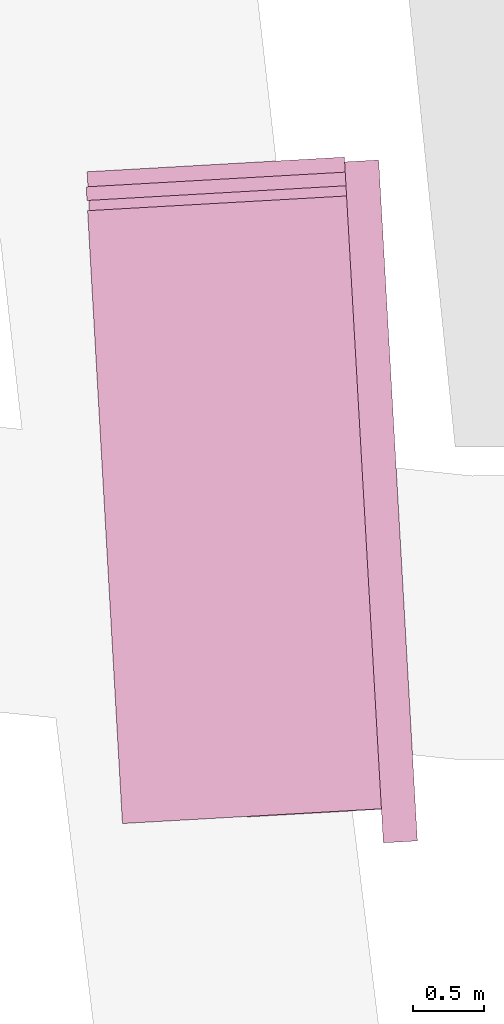
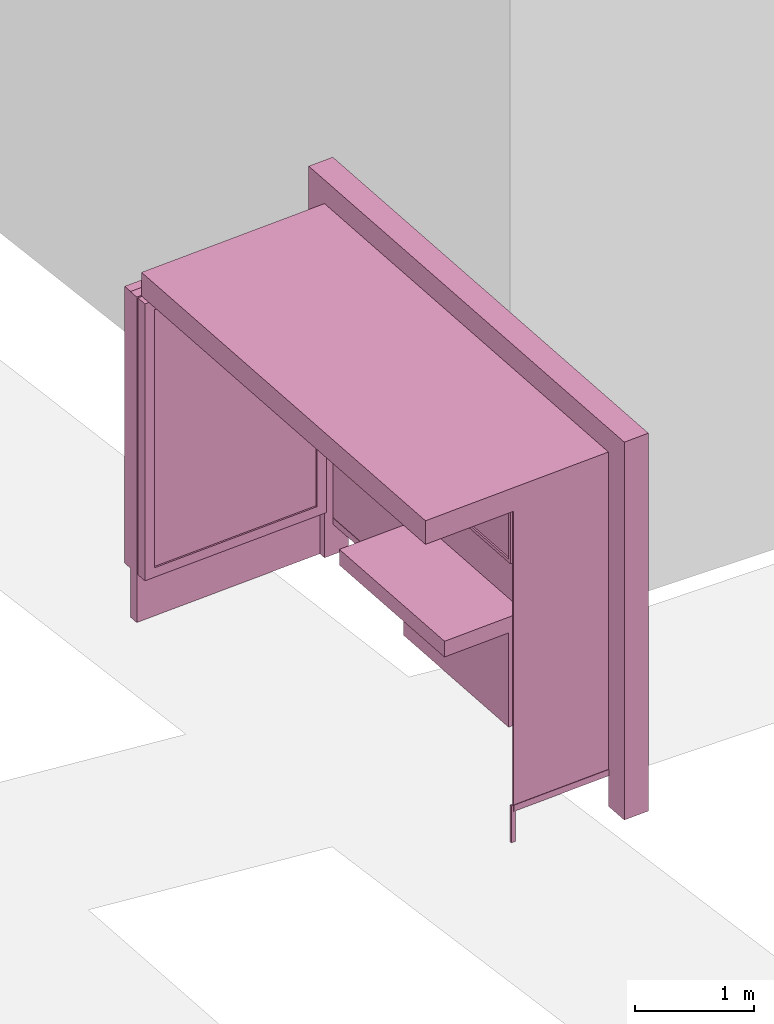
# One storey, part 32 of 200: 1 furnishing.
"""IFC4 building model written with IfcOpenShell, lengths in metres."""

import ifcopenshell
import ifcopenshell.guid

model = None  # the IFC model being written
_history = None  # IfcOwnerHistory: only IFC2X3 demands one
_inside = {}  # id of a spatial element -> (the spatial element, [elements in it])
_under = {}  # id of a project, library or spatial element -> (it, [spatial elements below it])
_declared = {}  # id of a project -> (the project, [libraries it declares])
_typed = {}  # id of a type object -> (the type object, [elements of that type])
_made_of = {}  # id of a material, layer set ... -> (it, [elements and type objects made of it])


def new_model(schema):
    """Start an empty IFC model of exactly this schema.

    Asked for "IFC4X3", IfcOpenShell would pick the latest addendum, in which some entities
    have other attributes; the version numbers below select the first issue.
    IFC2X3 requires an IfcOwnerHistory on every rooted entity: one is made here for all.
    """
    global model, _history
    if schema == "IFC4X3":
        model = ifcopenshell.file(schema_version=(4, 3, 0, 0))
    else:
        model = ifcopenshell.file(schema=schema)
    _inside.clear()
    _under.clear()
    _declared.clear()
    _typed.clear()
    _made_of.clear()
    _history = None
    if model.schema == "IFC2X3":
        org = make("IfcOrganization", Name="unknown")
        user = make(
            "IfcPersonAndOrganization",
            ThePerson=make("IfcPerson", FamilyName="unknown"),
            TheOrganization=org,
        )
        app = make(
            "IfcApplication",
            ApplicationDeveloper=org,
            Version="unknown",
            ApplicationFullName="unknown",
            ApplicationIdentifier="unknown",
        )
        _history = make(
            "IfcOwnerHistory",
            OwningUser=user,
            OwningApplication=app,
            ChangeAction="ADDED",
            CreationDate=0,
        )
    return model


def make(cls, **values):
    """One entity of the class cls with the attributes given. An attribute that is None is left unset."""
    return model.create_entity(
        cls, **{name: value for name, value in values.items() if value is not None}
    )


def rooted(cls, **values):
    """An entity with a GlobalId (a new one), such as an element, a storey or a relation."""
    return make(cls, GlobalId=ifcopenshell.guid.new(), OwnerHistory=_history, **values)


def si_unit(unit_type, name, prefix=None):
    """IfcSIUnit, for example si_unit("LENGTHUNIT", "METRE", prefix="MILLI")."""
    return make("IfcSIUnit", UnitType=unit_type, Prefix=prefix, Name=name)


def assignment(units):
    """IfcUnitAssignment: the units of a project."""
    return None if units is None else make("IfcUnitAssignment", Units=units)


def point(xyz):
    """IfcCartesianPoint."""
    return None if xyz is None else make("IfcCartesianPoint", Coordinates=xyz)


def direction(xyz):
    """IfcDirection."""
    return None if xyz is None else make("IfcDirection", DirectionRatios=xyz)


def frame(location, z_axis=None, x_axis=None):
    """IfcAxis2Placement3D, a coordinate frame: its origin and axes. An axis left out is left unset."""
    return make(
        "IfcAxis2Placement3D",
        Location=point(location),
        Axis=direction(z_axis),
        RefDirection=direction(x_axis),
    )


def origin_with_axes():
    """The frame at (0, 0, 0) with the z axis (0, 0, 1) and the x axis (1, 0, 0) written out."""
    return frame((0.0, 0.0, 0.0), z_axis=(0.0, 0.0, 1.0), x_axis=(1.0, 0.0, 0.0))


def place(relative_to, where):
    """IfcLocalPlacement: puts the frame where relative to a parent placement (None: the world)."""
    return make(
        "IfcLocalPlacement", PlacementRelTo=relative_to, RelativePlacement=where
    )


def context(
    kind, dimensions, precision=None, world=None, true_north=None, identifier=None
):
    """IfcGeometricRepresentationContext, for example the 3D "Model" context."""
    return make(
        "IfcGeometricRepresentationContext",
        ContextIdentifier=identifier,
        ContextType=kind,
        CoordinateSpaceDimension=dimensions,
        Precision=precision,
        WorldCoordinateSystem=world,
        TrueNorth=true_north,
    )


def subcontext(parent, identifier, kind, view, scale=None):
    """IfcGeometricRepresentationSubContext, for example "Body" below "Model"."""
    return make(
        "IfcGeometricRepresentationSubContext",
        ContextIdentifier=identifier,
        ContextType=kind,
        ParentContext=parent,
        TargetScale=scale,
        TargetView=view,
    )


def project(units=None, contexts=None):
    """IfcProject with its units and contexts."""
    return rooted(
        "IfcProject",
        Name="project",
        RepresentationContexts=contexts,
        UnitsInContext=assignment(units),
    )


def spatial(cls, under=None, at=None, **own):
    """A site, building, storey or space (cls), placed at a placement, below another one or the project."""
    s = rooted(cls, ObjectPlacement=at, **own)
    if under is not None:
        _under.setdefault(under.id(), (under, []))[1].append(s)
    return s


def point_list(points):
    """IfcCartesianPointList2D or 3D."""
    cls = (
        "IfcCartesianPointList2D" if len(points[0]) == 2 else "IfcCartesianPointList3D"
    )
    return make(cls, CoordList=points)


def triangles(points, corners, closed=None, point_numbers=None):
    """IfcTriangulatedFaceSet: each triangle names its three corners, points numbered from 1."""
    return make(
        "IfcTriangulatedFaceSet",
        Coordinates=point_list(points),
        Closed=closed,
        CoordIndex=corners,
        PnIndex=point_numbers,
    )


def shape(context_of_items, identifier, shape_type, items):
    """IfcShapeRepresentation: the items that make up one representation, for example the "Body"."""
    return make(
        "IfcShapeRepresentation",
        ContextOfItems=context_of_items,
        RepresentationIdentifier=identifier,
        RepresentationType=shape_type,
        Items=items,
    )


def material(Name=None, Category=None):
    """IfcMaterial."""
    return make("IfcMaterial", Name=Name, Category=Category)


def made_of(thing, what):
    """Note that an element or type object is made of a material, layer set ...; save() writes the relation."""
    if what is not None:
        _made_of.setdefault(what.id(), (what, []))[1].append(thing)
    return thing


def element(
    cls,
    number,
    at=None,
    inside=None,
    cuts=None,
    type_object=None,
    material=None,
    context=None,
    identifier="Body",
    shape_type=None,
    held_by="IfcProductDefinitionShape",
    body=None,
    shapes=None,
    **own,
):
    """One element of the class cls, such as IfcWall. Its Tag is "e" and its number.

    at: its placement. inside: the storey or other place that contains it. cuts: it is an
    opening in that element (IfcRelVoidsElement). A single representation is given by context,
    identifier, shape_type and body (its items); several are given by shapes. held_by: the class
    of the entity that holds the representations. save() writes the other relations.
    """
    e = rooted(cls, Tag="e%d" % number, ObjectPlacement=at, **own)
    if body is not None:
        shapes = [shape(context, identifier, shape_type, body)]
    if shapes is not None:
        e.Representation = make(held_by, Representations=shapes)
    if inside is not None:
        _inside.setdefault(inside.id(), (inside, []))[1].append(e)
    if cuts is not None:
        rooted(
            "IfcRelVoidsElement", RelatingBuildingElement=cuts, RelatedOpeningElement=e
        )
    if type_object is not None:
        _typed.setdefault(type_object.id(), (type_object, []))[1].append(e)
    return made_of(e, material)


def aggregate(whole, parts):
    """IfcRelAggregates: a whole, such as a stair, and the parts it consists of."""
    return rooted("IfcRelAggregates", RelatingObject=whole, RelatedObjects=parts)


def save(model, path):
    """Write the relations noted so far, then the file.

    IfcRelAggregates (storeys below a building ...), IfcRelContainedInSpatialStructure (elements
    in a storey), IfcRelDefinesByType, IfcRelAssociatesMaterial and IfcRelDeclares: one each for
    every whole, place, type object, material and project.
    """
    for whole, parts in _under.values():
        aggregate(whole, parts)
    for where, things in _inside.values():
        rooted(
            "IfcRelContainedInSpatialStructure",
            RelatedElements=things,
            RelatingStructure=where,
        )
    for kind, things in _typed.values():
        rooted("IfcRelDefinesByType", RelatedObjects=things, RelatingType=kind)
    for what, things in _made_of.values():
        rooted("IfcRelAssociatesMaterial", RelatedObjects=things, RelatingMaterial=what)
    for by, libraries in _declared.values():
        rooted("IfcRelDeclares", RelatingContext=by, RelatedDefinitions=libraries)
    model.write(path)


model = new_model("IFC4")

# Units and contexts
model_context = context("Model", 3, precision=1e-05, world=origin_with_axes())
body_context = subcontext(model_context, "Body", "Model", "MODEL_VIEW")
ifc_project = project(units=[si_unit("VOLUMEUNIT", "CUBIC_METRE"), si_unit("LENGTHUNIT", "METRE"), si_unit("AREAUNIT", "SQUARE_METRE")], contexts=[model_context])

# Site, building, storey
site_placement = place(None, origin_with_axes())
site = spatial("IfcSite", under=ifc_project, at=site_placement)
building_placement = place(site_placement, origin_with_axes())
building = spatial("IfcBuilding", under=site, at=building_placement, Name="Building")
storey_placement = place(building_placement, origin_with_axes())
storey = spatial("IfcBuildingStorey", under=building, at=storey_placement, Name="Ground")

# Furnishing
ifc_material = material(Name="busStop")
furnishing_placement = place(storey_placement, origin_with_axes())
element("IfcFurnishingElement", 1, at=furnishing_placement, inside=storey, material=ifc_material, Name="cw_instances_busStop_13", context=body_context, shape_type="Tessellation", body=[
    triangles([(391.9908575976121, -385.74871729315475, 3.3826375611235573), (394.30826542098004, -389.962715683179, 3.3826375611235573), (394.0620177534314, -385.63097864473866, 3.3826375611235573), (392.2371050666279, -390.0804545199297, 3.3826375611235573), (391.9908575013513, -385.7487172986269, 3.6236783199298275), (394.3082653247192, -389.9627156886512, 3.6236783199298275), (392.2371049703671, -390.0804545254019, 3.6236783199298275), (394.0620176571706, -385.63097865021086, 3.6236783199298275), (391.9908575976121, -385.74871729315475, 3.3826375611235573), (392.2371049703671, -390.0804545254019, 3.6236783199298275), (392.2371050666279, -390.0804545199297, 3.3826375611235573), (391.9908575013513, -385.7487172986269, 3.6236783199298275), (392.2371050666279, -390.0804545199297, 3.3826375611235573), (394.3082653247192, -389.9627156886512, 3.6236783199298275), (394.30826542098004, -389.962715683179, 3.3826375611235573), (392.2371049703671, -390.0804545254019, 3.6236783199298275), (394.30826542098004, -389.962715683179, 3.3826375611235573), (394.0620176571706, -385.63097865021086, 3.6236783199298275), (394.0620177534314, -385.63097864473866, 3.3826375611235573), (394.3082653247192, -389.9627156886512, 3.6236783199298275), (394.0620177534314, -385.63097864473866, 3.3826375611235573), (391.9908575013513, -385.7487172986269, 3.6236783199298275), (391.9908575976121, -385.74871729315475, 3.3826375611235573), (394.0620176571706, -385.63097865021086, 3.6236783199298275), (393.82136525931685, -385.64465914828, 3.864718677001767), (394.0483368001339, -385.39032644981205, 3.864718677001767), (394.06201728817075, -385.63097867118756, 3.864718677001767), (393.80768477128004, -385.4040069269045, 3.864718677001767), (393.82136525931685, -385.64465914828, 3.6236783199298275), (393.80768477128004, -385.4040069269045, 3.864718677001767), (393.82136525931685, -385.64465914828, 3.864718677001767), (393.80768477128004, -385.4040069269045, 3.6236783199298275), (394.0812931944808, -390.21704821138724, 3.6236783199298275), (394.32194541585636, -390.20336772335037, 3.864718677001767), (394.32194541585636, -390.20336772335037, 3.6236783199298275), (394.0812931944808, -390.21704821138724, 3.864718677001767), (394.3082649396759, -389.96271571053995, 3.6236783199298275), (394.32194541585636, -390.20336772335037, 3.864718677001767), (394.3082649396759, -389.96271571053995, 3.864718677001767), (394.32194541585636, -390.20336772335037, 3.6236783199298275), (394.04833697661206, -385.3903264397797, 3.6236783199298275), (393.80768477128004, -385.4040069269045, 3.864718677001767), (393.80768477128004, -385.4040069269045, 3.6236783199298275), (394.0483368001339, -385.39032644981205, 3.864718677001767), (394.067612910822, -389.9763961876324, 3.864718677001767), (394.3082649396759, -389.96271571053995, 3.864718677001767), (394.067612910822, -389.9763961876324, 3.6236783199298275), (394.067612910822, -389.9763961876324, 3.864718677001767), (394.04833697661206, -385.3903264397797, 3.6236783199298275), (394.06201728817075, -385.63097867118756, 3.864718677001767), (394.0483368001339, -385.39032644981205, 3.864718677001767), (394.06201728817075, -385.63097867118756, 3.6236783199298275), (394.0812931944808, -390.21704821138724, 3.864718677001767), (394.32194541585636, -390.20336772335037, 3.864718677001767), (394.0812931944808, -390.21704821138724, 3.6236783199298275), (394.0812931944808, -390.21704821138724, 3.864718677001767), (394.0483378429595, -385.39032639053, 9.480930192426488e-07), (393.80768591036644, -385.40400686215025, 8.998848996201414e-07), (394.06201833099635, -385.6309786119055, 9.480930192426488e-07), (394.0483378429595, -385.39032639053, 9.480930192426488e-07), (394.06201728817075, -385.63097867118756, 3.6236783199298275), (393.82136622192513, -385.6446590935581, 8.998848996201414e-07), (393.82136525931685, -385.64465914828, 3.6236783199298275), (394.06201833099635, -385.6309786119055, 9.480930192426488e-07), (393.80768591036644, -385.40400686215025, 8.998848996201414e-07), (393.82136622192513, -385.6446590935581, 8.998848996201414e-07), (394.0812942629677, -390.2170466215912, 8.998848996201414e-07), (394.3219464586819, -390.2033676640683, 9.480930192426488e-07), (394.0676137858752, -389.97639459273734, 8.998848996201414e-07), (394.0812942629677, -390.2170466215912, 8.998848996201414e-07), (394.067612910822, -389.9763961876324, 3.6236783199298275), (394.30826589494643, -389.96271411108467, 9.480930192426488e-07), (394.3082649396759, -389.96271571053995, 3.6236783199298275), (394.0676137858752, -389.97639459273734, 8.998848996201414e-07), (394.3219464586819, -390.2033676640683, 9.480930192426488e-07), (394.30826589494643, -389.96271411108467, 9.480930192426488e-07), (393.11772214302897, -390.0301441717224, 0.3459945917589383), (394.1623072118306, -389.97076207478796, 3.3826375611235573), (394.162308078178, -389.9707620255382, 0.34599476852204364), (393.11772135689887, -390.03014421641194, 3.3826375611235573), (394.16139604716227, -389.95471857085226, 0.34599476852204364), (393.11680932588314, -390.01410076172607, 3.3826375611235573), (393.11681011201324, -390.01410071703646, 0.3459945917589383), (394.16139518081485, -389.954718620102, 3.3826375611235573), (393.11681011201324, -390.01410071703646, 0.3459945917589383), (393.11772135689887, -390.03014421641194, 3.3826375611235573), (393.11772214302897, -390.0301441717224, 0.3459945917589383), (393.11680932588314, -390.01410076172607, 3.3826375611235573), (394.1611680337082, -389.95070760690913, 0.313856054245785), (393.1179501936691, -390.0341549404078, 0.3138558614133065), (394.1625360806878, -389.9747727969597, 0.313856054245785), (393.1165821466895, -390.0100897503572, 0.3138558614133065), (394.1611680337082, -389.95070760690913, 0.37813349886767544), (393.11795017762563, -390.03415494131985, 0.37813330603519696), (393.116582130646, -390.0100897512692, 0.37813330603519696), (394.1625360806878, -389.9747727969597, 0.37813349886767544), (394.1611680337082, -389.95070760690913, 0.313856054245785), (393.116582130646, -390.0100897512692, 0.37813330603519696), (393.1165821466895, -390.0100897503572, 0.3138558614133065), (394.1611680337082, -389.95070760690913, 0.37813349886767544), (393.1179501936691, -390.0341549404078, 0.3138558614133065), (394.1625360806878, -389.9747727969597, 0.37813349886767544), (394.1625360806878, -389.9747727969597, 0.313856054245785), (393.11795017762563, -390.03415494131985, 0.37813330603519696), (393.11795017762563, -390.03415494131985, 0.37813330603519696), (393.1165821466895, -390.0100897503572, 0.3138558614133065), (393.116582130646, -390.0100897512692, 0.37813330603519696), (393.1179501936691, -390.0341549404078, 0.3138558614133065), (393.09470188118246, -390.01507085808356, 0.37813330603519696), (393.13983020115404, -390.0291721251504, 0.37813330603519696), (393.0956462902437, -390.03168387202385, 0.37813330603519696), (393.1388857920928, -390.0125591112101, 0.37813330603519696), (393.094702137878, -390.01507084349106, 1.446243588675227e-07), (393.0956462902437, -390.03168387202385, 0.37813330603519696), (393.0956465469392, -390.03168385743135, 1.446243588675227e-07), (393.09470188118246, -390.01507085808356, 0.37813330603519696), (393.0956465469392, -390.03168385743135, 1.446243588675227e-07), (393.13983020115404, -390.0291721251504, 0.37813330603519696), (393.13983031345833, -390.02917211876616, 1.6069373207502523e-07), (393.0956462902437, -390.03168387202385, 0.37813330603519696), (393.13983031345833, -390.02917211876616, 1.6069373207502523e-07), (393.1388857920928, -390.0125591112101, 0.37813330603519696), (393.1388859043971, -390.0125591048259, 1.6069373207502523e-07), (393.13983020115404, -390.0291721251504, 0.37813330603519696), (393.1388859043971, -390.0125591048259, 1.6069373207502523e-07), (393.09470188118246, -390.01507085808356, 0.37813330603519696), (393.094702137878, -390.01507084349106, 1.446243588675227e-07), (393.1388857920928, -390.0125591112101, 0.37813330603519696), (393.82979524786504, -386.9528598347399, 1.1248564780513874), (394.07418741920685, -388.5484984902926, 1.1248565744676267), (393.9209979593378, -388.5572069350397, 1.1248564780513874), (393.9829845152124, -386.94415140093724, 1.1248565744676267), (393.92099815185946, -388.5572069240953, 4.981505694325782e-07), (393.82979524786504, -386.9528598347399, 0.964162810253855), (393.9209979593378, -388.5572069350397, 0.964162810253855), (393.8297955847779, -386.95285981558726, 4.981505694325782e-07), (394.07418780425013, -388.5484984684038, 5.302893158475833e-07), (393.9209979593378, -388.5572069350397, 0.964162810253855), (394.07418741920685, -388.5484984902926, 0.9641629066700942), (393.92099815185946, -388.5572069240953, 4.981505694325782e-07), (393.9829849002557, -386.94415137904844, 5.302893158475833e-07), (394.07418741920685, -388.5484984902926, 0.9641629066700942), (393.9829845152124, -386.94415140093724, 0.9641629066700942), (394.07418780425013, -388.5484984684038, 5.302893158475833e-07), (393.8297955847779, -386.95285981558726, 4.981505694325782e-07), (393.9829845152124, -386.94415140093724, 0.9641629066700942), (393.82979524786504, -386.9528598347399, 0.964162810253855), (393.9829849002557, -386.94415137904844, 5.302893158475833e-07), (393.2792591943362, -388.59368820850233, 1.124856381635148), (393.18805640264605, -386.9893411127627, 0.9641627138376155), (393.18805637055914, -386.98934111458675, 1.124856381635148), (393.2792592103797, -388.5936882075903, 0.9641627138376155), (394.07418741920685, -388.5484984902926, 1.1248565744676267), (393.9209979593378, -388.5572069350397, 1.1248564780513874), (393.9829845152124, -386.94415140093724, 1.1248565744676267), (394.07418741920685, -388.5484984902926, 1.1248565744676267), (393.82979524786504, -386.9528598347399, 1.1248564780513874), (393.9829845152124, -386.94415140093724, 1.1248565744676267), (393.18805637055914, -386.98934111458675, 1.124856381635148), (393.2792591943362, -388.59368820850233, 1.124856381635148), (393.18805640264605, -386.9893411127627, 0.9641627138376155), (393.18805637055914, -386.98934111458675, 1.124856381635148), (393.2792591943362, -388.59368820850233, 1.124856381635148), (393.2792592103797, -388.5936882075903, 0.9641627138376155), (393.9001257121857, -385.50028280697956, 0.34599476852204364), (394.1611398606688, -390.09179435579534, 3.503157940526693), (394.16114080723355, -390.0917943019855, 0.34599476852204364), (393.9001250383599, -385.50028284528486, 3.503157940526693), (394.17718427796297, -390.0908822700577, 0.34599476852204364), (393.9161684930458, -385.4993708142691, 3.503157940526693), (393.91616916687155, -385.4993707759638, 0.34599476852204364), (394.17718331535474, -390.0908823247796, 3.503157940526693), (393.71041619577414, -385.39173345643263, 0.5810001600002933), (392.0846678067081, -385.4841532614958, 3.2193552137185355), (392.0846683842731, -385.48415322866265, 0.5809998707515756), (393.7104155861223, -385.39173349108984, 3.2193552137185355), (393.80576498913473, -385.3702178101801, 0.4845839046859049), (392.08375635325734, -385.4681097739768, 0.5809998707515756), (391.98749553849876, -385.47358043594147, 0.48458358329844076), (393.7095041647584, -385.3756900017467, 0.5810001600002933), (392.0837557756924, -385.4681098068099, 3.2193552137185355), (391.9874947587944, -385.4735820093209, 3.3157713565473115), (393.70950355510655, -385.3756900364039, 3.2193552137185355), (393.80576433135246, -385.37021784757343, 3.3157713565473115), (393.7095041647584, -385.3756900017467, 0.5810001600002933), (392.0846683842731, -385.48415322866265, 0.5809998707515756), (392.08375635325734, -385.4681097739768, 0.5809998707515756), (393.71041619577414, -385.39173345643263, 0.5810001600002933), (392.08375635325734, -385.4681097739768, 0.5809998707515756), (392.0846678067081, -385.4841532614958, 3.2193552137185355), (392.0837557756924, -385.4681098068099, 3.2193552137185355), (392.0846683842731, -385.48415322866265, 0.5809998707515756), (392.0837557756924, -385.4681098068099, 3.2193552137185355), (393.7104155861223, -385.39173349108984, 3.2193552137185355), (393.70950355510655, -385.3756900364039, 3.2193552137185355), (392.0846678067081, -385.4841532614958, 3.2193552137185355), (393.70950355510655, -385.3756900364039, 3.2193552137185355), (393.71041619577414, -385.39173345643263, 0.5810001600002933), (393.7095041647584, -385.3756900017467, 0.5810001600002933), (393.7104155861223, -385.39173349108984, 3.2193552137185355), (392.00501689677304, -385.7818123455811, 3.3157713565473115), (393.80576433135246, -385.37021784757343, 3.3157713565473115), (393.82328618054856, -385.6784482002502, 3.3157713565473115), (391.9874947587944, -385.4735820093209, 3.3157713565473115), (392.00501776312046, -385.7818122963314, 0.48458358329844076), (391.9874947587944, -385.4735820093209, 3.3157713565473115), (392.00501689677304, -385.7818123455811, 3.3157713565473115), (391.98749553849876, -385.47358043594147, 0.48458358329844076), (393.80576498913473, -385.3702178101801, 0.4845839046859049), (393.82328618054856, -385.6784482002502, 3.3157713565473115), (393.80576433135246, -385.37021784757343, 3.3157713565473115), (393.8232869506352, -385.67844815647265, 0.4845839046859049), (393.72611412733005, -385.66787689152926, 0.5810001600002933), (392.10036588265524, -385.7602966883842, 3.2193552137185355), (393.7261133251565, -385.66787693713087, 3.2193552137185355), (392.1003664602202, -385.76029665555103, 0.5809998707515756), (393.8232869506352, -385.67844815647265, 0.4845839046859049), (392.1012784912359, -385.77634011023696, 0.5809998707515756), (393.7270261583458, -385.6839203462152, 0.5810001600002933), (392.00501776312046, -385.7818122963314, 0.48458358329844076), (392.10127791367097, -385.7763401430701, 3.2193552137185355), (392.00501689677304, -385.7818123455811, 3.3157713565473115), (393.72702535617225, -385.6839203918168, 3.2193552137185355), (393.82328618054856, -385.6784482002502, 3.3157713565473115), (393.7270261583458, -385.6839203462152, 0.5810001600002933), (392.1003664602202, -385.76029665555103, 0.5809998707515756), (393.72611412733005, -385.66787689152926, 0.5810001600002933), (392.1012784912359, -385.77634011023696, 0.5809998707515756), (392.1012784912359, -385.77634011023696, 0.5809998707515756), (392.10036588265524, -385.7602966883842, 3.2193552137185355), (392.1003664602202, -385.76029665555103, 0.5809998707515756), (392.10127791367097, -385.7763401430701, 3.2193552137185355), (392.10127791367097, -385.7763401430701, 3.2193552137185355), (393.7261133251565, -385.66787693713087, 3.2193552137185355), (392.10036588265524, -385.7602966883842, 3.2193552137185355), (393.72702535617225, -385.6839203918168, 3.2193552137185355), (393.72702535617225, -385.6839203918168, 3.2193552137185355), (393.72611412733005, -385.66787689152926, 0.5810001600002933), (393.7261133251565, -385.66787693713087, 3.2193552137185355), (393.7270261583458, -385.6839203462152, 0.5810001600002933), (391.98128135813386, -385.58026253506057, 3.3287619342644956), (393.81726149338897, -385.57246337976125, 3.3287619342644956), (391.9867534575853, -385.6765217390464, 3.3287619342644956), (393.81178930729453, -385.47620265164574, 3.3287619342644956), (391.98128193437225, -385.58026078010386, 0.0), (391.9867534575853, -385.6765217390464, 3.3287619342644956), (391.98675413141103, -385.67652170074103, 0.0), (391.98128135813386, -385.58026253506057, 3.3287619342644956), (391.98675413141103, -385.67652170074103, 0.0), (393.81726149338897, -385.57246337976125, 3.3287619342644956), (393.8172622474321, -385.57246333689574, 5.142199426400808e-07), (391.9867534575853, -385.6765217390464, 3.3287619342644956), (393.8172622474321, -385.57246333689574, 5.142199426400808e-07), (393.81178930729453, -385.47620265164574, 3.3287619342644956), (393.81179006133766, -385.4762026087803, 5.142199426400808e-07), (393.81726149338897, -385.57246337976125, 3.3287619342644956), (393.81179006133766, -385.4762026087803, 5.142199426400808e-07), (391.98128135813386, -385.58026253506057, 3.3287619342644956), (391.98128193437225, -385.58026078010386, 0.0), (393.81178930729453, -385.47620265164574, 3.3287619342644956), (393.8961148445033, -385.5005108149615, 0.313856054245785), (394.1755480181052, -389.9913147392367, 0.313856054245785), (393.92018013081474, -385.4991427625097, 0.313856054245785), (394.15148284409804, -389.9926827853043, 0.313856054245785), (393.8961148445033, -385.5005108149615, 0.37813349886767544), (394.1755480181052, -389.9913147392367, 0.37813349886767544), (394.15148284409804, -389.9926827853043, 0.37813349886767544), (393.92018013081474, -385.4991427625097, 0.37813349886767544), (393.8961148445033, -385.5005108149615, 0.313856054245785), (394.15148284409804, -389.9926827853043, 0.37813349886767544), (394.15148284409804, -389.9926827853043, 0.313856054245785), (393.8961148445033, -385.5005108149615, 0.37813349886767544), (394.1755480181052, -389.9913147392367, 0.313856054245785), (393.92018013081474, -385.4991427625097, 0.37813349886767544), (393.92018013081474, -385.4991427625097, 0.313856054245785), (394.1755480181052, -389.9913147392367, 0.37813349886767544), (393.99119612758204, -387.10463824884766, 1.5290613779533648), (394.06415800888976, -388.38811596154756, 2.8146110577904615), (393.9911957425387, -387.1046382707364, 2.8146110577904615), (394.0641583939331, -388.38811593965875, 1.5290613779533648), (393.9795346444629, -387.1374918266432, 1.5612002850621018), (394.04884841227897, -388.35679562342654, 2.7824723435142027), (394.04884897380043, -388.35679559150543, 1.5612002850621018), (393.9795344519412, -387.1374918375876, 2.7824723435142027), (393.99119612758204, -387.10463824884766, 1.5290613779533648), (394.03462939136045, -388.3897945909678, 1.5290613779533648), (394.0641583939331, -388.38811593965875, 1.5290613779533648), (393.96166731753107, -387.10631688921234, 1.5290613779533648), (394.0641583939331, -388.38811593965875, 1.5290613779533648), (394.0346292148823, -388.3897946010002, 2.8146110577904615), (394.06415800888976, -388.38811596154756, 2.8146110577904615), (394.03462939136045, -388.3897945909678, 1.5290613779533648), (394.06415800888976, -388.38811596154756, 2.8146110577904615), (393.96166693248773, -387.1063169111011, 2.8146110577904615), (393.9911957425387, -387.1046382707364, 2.8146110577904615), (394.0346292148823, -388.3897946010002, 2.8146110577904615), (393.9911957425387, -387.1046382707364, 2.8146110577904615), (393.96166731753107, -387.10631688921234, 1.5290613779533648), (393.99119612758204, -387.10463824884766, 1.5290613779533648), (393.96166693248773, -387.1063169111011, 2.8146110577904615), (394.0854582073739, -388.7627990215493, 1.5290613779533648), (394.13105903914794, -389.5649726980571, 2.8146110577904615), (394.08545763528116, -388.76279915064333, 2.8146110577904615), (394.1310594241912, -389.56497267616834, 1.5290613779533648), (394.0737969249847, -388.7956527327917, 1.5612002850621018), (394.1157497340557, -389.53365239165, 2.7824723435142027), (394.1157500228382, -389.5336523752334, 1.5612002850621018), (394.0737963634632, -388.7956527647128, 2.7824723435142027), (394.0854582073739, -388.7627990215493, 1.5290613779533648), (394.10153063018373, -389.56665131562096, 1.5290613779533648), (394.1310594241912, -389.56497267616834, 1.5290613779533648), (394.05592920480126, -388.7644776728584, 1.5290613779533648), (394.1310594241912, -389.56497267616834, 1.5290613779533648), (394.10153024514045, -389.5666513375097, 2.8146110577904615), (394.13105903914794, -389.5649726980571, 2.8146110577904615), (394.10153063018373, -389.56665131562096, 1.5290613779533648), (394.13105903914794, -389.5649726980571, 2.8146110577904615), (394.0559288412736, -388.76447779009595, 2.8146110577904615), (394.08545763528116, -388.76279915064333, 2.8146110577904615), (394.10153024514045, -389.5666513375097, 2.8146110577904615), (394.08545763528116, -388.76279915064333, 2.8146110577904615), (394.05592920480126, -388.7644776728584, 1.5290613779533648), (394.0854582073739, -388.7627990215493, 1.5290613779533648), (394.0559288412736, -388.76447779009595, 2.8146110577904615), (393.96166731753107, -387.10631688921234, 1.5290613779533648), (394.0328054228537, -388.35770762799336, 1.5612002850621018), (394.03462939136045, -388.3897945909678, 1.5290613779533648), (393.9634913822986, -387.1384038467146, 1.5612002850621018), (394.0328051501147, -388.3577076434979, 2.7824723435142027), (394.0346292148823, -388.3897946010002, 2.8146110577904615), (393.9634909972553, -387.13840386860335, 2.7824723435142027), (393.96166693248773, -387.1063169111011, 2.8146110577904615), (394.05592920480126, -388.7644776728584, 1.5290613779533648), (394.09970656815227, -389.5345644062491, 1.5612002850621018), (394.10153063018373, -389.56665131562096, 1.5290613779533648), (394.0577532777771, -388.79656477475186, 1.5612002850621018), (394.09970618310894, -389.53456442813786, 2.7824723435142027), (394.10153024514045, -389.5666513375097, 2.8146110577904615), (394.05775290877733, -388.7965647957286, 2.7824723435142027), (394.0559288412736, -388.76447779009595, 2.8146110577904615), (393.9634913822986, -387.1384038467146, 1.5612002850621018), (394.04884897380043, -388.35679559150543, 1.5612002850621018), (394.0328054228537, -388.35770762799336, 1.5612002850621018), (393.9795346444629, -387.1374918266432, 1.5612002850621018), (394.0328054228537, -388.35770762799336, 1.5612002850621018), (394.04884841227897, -388.35679562342654, 2.7824723435142027), (394.0328051501147, -388.3577076434979, 2.7824723435142027), (394.04884897380043, -388.35679559150543, 1.5612002850621018), (394.0328051501147, -388.3577076434979, 2.7824723435142027), (393.9795344519412, -387.1374918375876, 2.7824723435142027), (393.9634909972553, -387.13840386860335, 2.7824723435142027), (394.04884841227897, -388.35679562342654, 2.7824723435142027), (393.9634909972553, -387.13840386860335, 2.7824723435142027), (393.9795346444629, -387.1374918266432, 1.5612002850621018), (393.9634913822986, -387.1384038467146, 1.5612002850621018), (393.9795344519412, -387.1374918375876, 2.7824723435142027), (394.0577532777771, -388.79656477475186, 1.5612002850621018), (394.1157500228382, -389.5336523752334, 1.5612002850621018), (394.09970656815227, -389.5345644062491, 1.5612002850621018), (394.0737969249847, -388.7956527327917, 1.5612002850621018), (394.09970656815227, -389.5345644062491, 1.5612002850621018), (394.1157497340557, -389.53365239165, 2.7824723435142027), (394.09970618310894, -389.53456442813786, 2.7824723435142027), (394.1157500228382, -389.5336523752334, 1.5612002850621018), (394.09970618310894, -389.53456442813786, 2.7824723435142027), (394.0737963634632, -388.7956527647128, 2.7824723435142027), (394.05775290877733, -388.7965647957286, 2.7824723435142027), (394.1157497340557, -389.53365239165, 2.7824723435142027), (394.05775290877733, -388.7965647957286, 2.7824723435142027), (394.0737969249847, -388.7956527327917, 1.5612002850621018), (394.0577532777771, -388.79656477475186, 1.5612002850621018), (394.0737963634632, -388.7956527647128, 2.7824723435142027)], [[1, 3, 2], [2, 4, 1], [5, 7, 6], [6, 8, 5], [9, 11, 10], [10, 12, 9], [13, 15, 14], [14, 16, 13], [17, 19, 18], [18, 20, 17], [21, 23, 22], [22, 24, 21], [25, 27, 26], [26, 28, 25], [29, 31, 30], [30, 32, 29], [33, 35, 34], [34, 36, 33], [37, 39, 38], [38, 40, 37], [41, 43, 42], [42, 44, 41], [45, 46, 27], [27, 25, 45], [47, 48, 31], [31, 29, 47], [49, 51, 50], [50, 52, 49], [52, 50, 39], [39, 37, 52], [53, 54, 46], [46, 45, 53], [55, 56, 48], [48, 47, 55], [43, 41, 57], [57, 58, 43], [49, 52, 59], [59, 60, 49], [61, 63, 62], [62, 64, 61], [29, 32, 65], [65, 66, 29], [35, 33, 67], [67, 68, 35], [55, 47, 69], [69, 70, 55], [71, 73, 72], [72, 74, 71], [37, 40, 75], [75, 76, 37], [77, 79, 78], [78, 80, 77], [81, 83, 82], [82, 84, 81], [85, 87, 86], [86, 88, 85], [89, 91, 90], [90, 92, 89], [93, 95, 94], [94, 96, 93], [97, 99, 98], [98, 100, 97], [101, 103, 102], [102, 104, 101], [105, 107, 106], [106, 108, 105], [109, 111, 110], [110, 112, 109], [113, 115, 114], [114, 116, 113], [117, 119, 118], [118, 120, 117], [121, 123, 122], [122, 124, 121], [125, 127, 126], [126, 128, 125], [129, 131, 130], [130, 132, 129], [133, 135, 134], [134, 136, 133], [137, 139, 138], [138, 140, 137], [141, 143, 142], [142, 144, 141], [145, 147, 146], [146, 148, 145], [149, 151, 150], [150, 152, 149], [153, 154, 138], [138, 139, 153], [155, 156, 142], [142, 143, 155], [157, 158, 146], [146, 147, 157], [131, 129, 159], [159, 160, 131], [157, 147, 161], [161, 162, 157], [138, 154, 163], [163, 164, 138], [165, 167, 166], [166, 168, 165], [169, 171, 170], [170, 172, 169], [173, 175, 174], [174, 176, 173], [177, 179, 178], [178, 180, 177], [179, 182, 181], [181, 178, 179], [182, 184, 183], [183, 181, 182], [184, 177, 180], [180, 183, 184], [185, 187, 186], [186, 188, 185], [189, 191, 190], [190, 192, 189], [193, 195, 194], [194, 196, 193], [197, 199, 198], [198, 200, 197], [201, 203, 202], [202, 204, 201], [205, 207, 206], [206, 208, 205], [209, 211, 210], [210, 212, 209], [213, 215, 214], [214, 216, 213], [217, 219, 218], [218, 220, 217], [220, 218, 221], [221, 222, 220], [222, 221, 223], [223, 224, 222], [224, 223, 219], [219, 217, 224], [225, 227, 226], [226, 228, 225], [229, 231, 230], [230, 232, 229], [233, 235, 234], [234, 236, 233], [237, 239, 238], [238, 240, 237], [241, 243, 242], [242, 244, 241], [245, 247, 246], [246, 248, 245], [249, 251, 250], [250, 252, 249], [253, 255, 254], [254, 256, 253], [257, 259, 258], [258, 260, 257], [261, 263, 262], [262, 264, 261], [265, 267, 266], [266, 268, 265], [269, 271, 270], [270, 272, 269], [273, 275, 274], [274, 276, 273], [277, 279, 278], [278, 280, 277], [281, 283, 282], [282, 284, 281], [285, 287, 286], [286, 288, 285], [289, 291, 290], [290, 292, 289], [293, 295, 294], [294, 296, 293], [297, 299, 298], [298, 300, 297], [301, 303, 302], [302, 304, 301], [305, 307, 306], [306, 308, 305], [309, 311, 310], [310, 312, 309], [313, 315, 314], [314, 316, 313], [317, 319, 318], [318, 320, 317], [321, 323, 322], [322, 324, 321], [325, 327, 326], [326, 328, 325], [327, 330, 329], [329, 326, 327], [330, 332, 331], [331, 329, 330], [332, 325, 328], [328, 331, 332], [333, 335, 334], [334, 336, 333], [335, 338, 337], [337, 334, 335], [338, 340, 339], [339, 337, 338], [340, 333, 336], [336, 339, 340], [341, 343, 342], [342, 344, 341], [345, 347, 346], [346, 348, 345], [349, 351, 350], [350, 352, 349], [353, 355, 354], [354, 356, 353], [357, 359, 358], [358, 360, 357], [361, 363, 362], [362, 364, 361], [365, 367, 366], [366, 368, 365], [369, 371, 370], [370, 372, 369]], closed=True),
])

save(model, "model.ifc")
